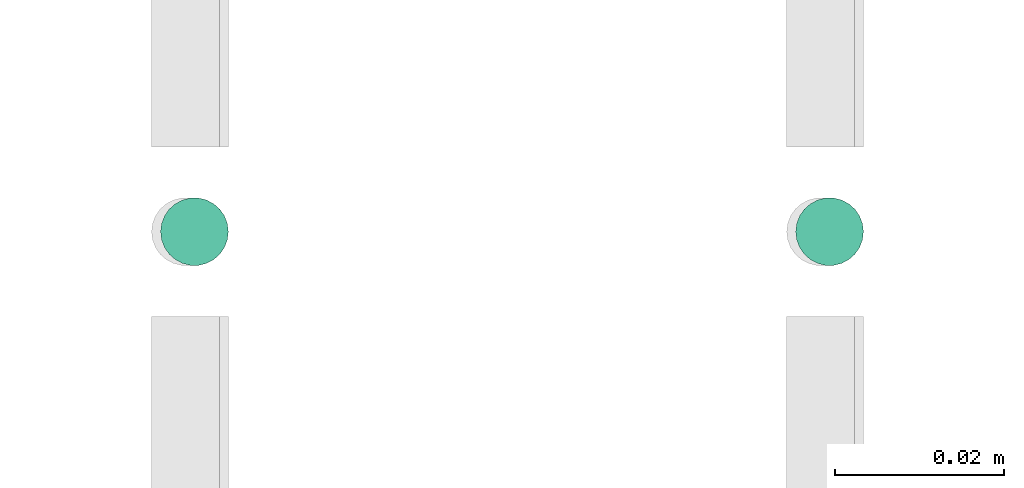
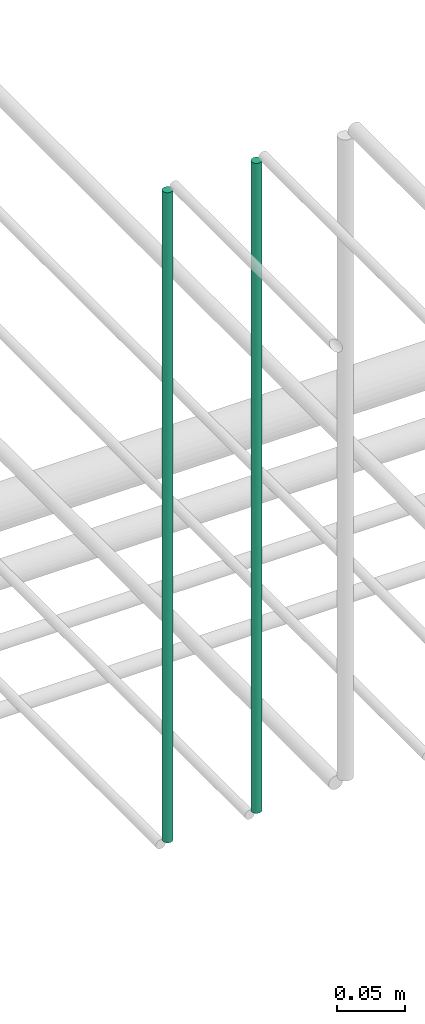
# One storey, part 173 of 331: 2 flow segments.
"""IFC2X3 building model written with IfcOpenShell, lengths in millimetres."""

import ifcopenshell
import ifcopenshell.guid

model = None  # the IFC model being written
_history = None  # IfcOwnerHistory: only IFC2X3 demands one
_inside = {}  # id of a spatial element -> (the spatial element, [elements in it])
_under = {}  # id of a project, library or spatial element -> (it, [spatial elements below it])
_declared = {}  # id of a project -> (the project, [libraries it declares])
_typed = {}  # id of a type object -> (the type object, [elements of that type])
_made_of = {}  # id of a material, layer set ... -> (it, [elements and type objects made of it])


def new_model(schema):
    """Start an empty IFC model of exactly this schema.

    Asked for "IFC4X3", IfcOpenShell would pick the latest addendum, in which some entities
    have other attributes; the version numbers below select the first issue.
    IFC2X3 requires an IfcOwnerHistory on every rooted entity: one is made here for all.
    """
    global model, _history
    if schema == "IFC4X3":
        model = ifcopenshell.file(schema_version=(4, 3, 0, 0))
    else:
        model = ifcopenshell.file(schema=schema)
    _inside.clear()
    _under.clear()
    _declared.clear()
    _typed.clear()
    _made_of.clear()
    _history = None
    if model.schema == "IFC2X3":
        org = make("IfcOrganization", Name="unknown")
        user = make(
            "IfcPersonAndOrganization",
            ThePerson=make("IfcPerson", FamilyName="unknown"),
            TheOrganization=org,
        )
        app = make(
            "IfcApplication",
            ApplicationDeveloper=org,
            Version="unknown",
            ApplicationFullName="unknown",
            ApplicationIdentifier="unknown",
        )
        _history = make(
            "IfcOwnerHistory",
            OwningUser=user,
            OwningApplication=app,
            ChangeAction="ADDED",
            CreationDate=0,
        )
    return model


def make(cls, **values):
    """One entity of the class cls with the attributes given. An attribute that is None is left unset."""
    return model.create_entity(
        cls, **{name: value for name, value in values.items() if value is not None}
    )


def entity(cls, *values):
    """Any entity or typed value of the class cls, its attributes in the order of the schema. None: left unset."""
    e = model.create_entity(cls)
    for i, value in enumerate(values):
        if value is not None:
            e[i] = value
    return e


def rooted(cls, **values):
    """An entity with a GlobalId (a new one), such as an element, a storey or a relation."""
    return make(cls, GlobalId=ifcopenshell.guid.new(), OwnerHistory=_history, **values)


def si_unit(unit_type, name, prefix=None):
    """IfcSIUnit, for example si_unit("LENGTHUNIT", "METRE", prefix="MILLI")."""
    return make("IfcSIUnit", UnitType=unit_type, Prefix=prefix, Name=name)


def converted_unit(unit_type, name, factor, base, dimensions=None, offset=None):
    """IfcConversionBasedUnit, such as the inch: factor (a typed value) times the base unit."""
    return make(
        "IfcConversionBasedUnit"
        if offset is None
        else "IfcConversionBasedUnitWithOffset",
        ConversionOffset=offset,
        Dimensions=None
        if dimensions is None
        else entity("IfcDimensionalExponents", *dimensions),
        UnitType=unit_type,
        Name=name,
        ConversionFactor=make(
            "IfcMeasureWithUnit", ValueComponent=factor, UnitComponent=base
        ),
    )


def derived_unit(unit_type, elements):
    """IfcDerivedUnit: a product of units, each with its exponent."""
    return make(
        "IfcDerivedUnit",
        Elements=[
            make("IfcDerivedUnitElement", Unit=unit, Exponent=power)
            for unit, power in elements
        ],
        UnitType=unit_type,
    )


def assignment(units):
    """IfcUnitAssignment: the units of a project."""
    return None if units is None else make("IfcUnitAssignment", Units=units)


def point(xyz):
    """IfcCartesianPoint."""
    return None if xyz is None else make("IfcCartesianPoint", Coordinates=xyz)


def direction(xyz):
    """IfcDirection."""
    return None if xyz is None else make("IfcDirection", DirectionRatios=xyz)


def frame(location, z_axis=None, x_axis=None):
    """IfcAxis2Placement3D, a coordinate frame: its origin and axes. An axis left out is left unset."""
    return make(
        "IfcAxis2Placement3D",
        Location=point(location),
        Axis=direction(z_axis),
        RefDirection=direction(x_axis),
    )


def frame_2d(location, x_axis=None):
    """IfcAxis2Placement2D, a coordinate frame in the plane: its origin and x axis."""
    return make(
        "IfcAxis2Placement2D", Location=point(location), RefDirection=direction(x_axis)
    )


def origin():
    """The frame at (0, 0, 0) with its axes left unset."""
    return frame((0.0, 0.0, 0.0))


def origin_2d_with_axis():
    """The frame at (0, 0) in the plane with the x axis (1, 0) written out."""
    return frame_2d((0.0, 0.0), x_axis=(1.0, 0.0))


def place(relative_to, where):
    """IfcLocalPlacement: puts the frame where relative to a parent placement (None: the world)."""
    return make(
        "IfcLocalPlacement", PlacementRelTo=relative_to, RelativePlacement=where
    )


def context(
    kind, dimensions, precision=None, world=None, true_north=None, identifier=None
):
    """IfcGeometricRepresentationContext, for example the 3D "Model" context."""
    return make(
        "IfcGeometricRepresentationContext",
        ContextIdentifier=identifier,
        ContextType=kind,
        CoordinateSpaceDimension=dimensions,
        Precision=precision,
        WorldCoordinateSystem=world,
        TrueNorth=true_north,
    )


def subcontext(parent, identifier, kind, view, scale=None):
    """IfcGeometricRepresentationSubContext, for example "Body" below "Model"."""
    return make(
        "IfcGeometricRepresentationSubContext",
        ContextIdentifier=identifier,
        ContextType=kind,
        ParentContext=parent,
        TargetScale=scale,
        TargetView=view,
    )


def project(units=None, contexts=None):
    """IfcProject with its units and contexts."""
    return rooted(
        "IfcProject",
        Name="project",
        RepresentationContexts=contexts,
        UnitsInContext=assignment(units),
    )


def spatial(cls, under=None, at=None, **own):
    """A site, building, storey or space (cls), placed at a placement, below another one or the project."""
    s = rooted(cls, ObjectPlacement=at, **own)
    if under is not None:
        _under.setdefault(under.id(), (under, []))[1].append(s)
    return s


def profile(cls, at=None, kind="AREA", **sizes):
    """A parametric profile (cls). Its sizes go by their IFC names, for example OverallWidth=200.0."""
    return make(cls, ProfileType=kind, Position=at, **sizes)


def circle(**sizes):
    """IfcCircleProfileDef."""
    return profile("IfcCircleProfileDef", **sizes)


def extrude(swept, where, along, depth):
    """IfcExtrudedAreaSolid: the profile swept, set in the frame where, extruded along a direction by depth."""
    return make(
        "IfcExtrudedAreaSolid",
        SweptArea=swept,
        Position=where,
        ExtrudedDirection=direction(along),
        Depth=depth,
    )


def shape(context_of_items, identifier, shape_type, items):
    """IfcShapeRepresentation: the items that make up one representation, for example the "Body"."""
    return make(
        "IfcShapeRepresentation",
        ContextOfItems=context_of_items,
        RepresentationIdentifier=identifier,
        RepresentationType=shape_type,
        Items=items,
    )


def made_of(thing, what):
    """Note that an element or type object is made of a material, layer set ...; save() writes the relation."""
    if what is not None:
        _made_of.setdefault(what.id(), (what, []))[1].append(thing)
    return thing


def type_object(cls, material=None, **own):
    """A type object (cls), such as IfcWallType, which elements share."""
    return made_of(rooted(cls, **own), material)


def element(
    cls,
    number,
    at=None,
    inside=None,
    cuts=None,
    type_object=None,
    material=None,
    context=None,
    identifier="Body",
    shape_type=None,
    held_by="IfcProductDefinitionShape",
    body=None,
    shapes=None,
    **own,
):
    """One element of the class cls, such as IfcWall. Its Tag is "e" and its number.

    at: its placement. inside: the storey or other place that contains it. cuts: it is an
    opening in that element (IfcRelVoidsElement). A single representation is given by context,
    identifier, shape_type and body (its items); several are given by shapes. held_by: the class
    of the entity that holds the representations. save() writes the other relations.
    """
    e = rooted(cls, Tag="e%d" % number, ObjectPlacement=at, **own)
    if body is not None:
        shapes = [shape(context, identifier, shape_type, body)]
    if shapes is not None:
        e.Representation = make(held_by, Representations=shapes)
    if inside is not None:
        _inside.setdefault(inside.id(), (inside, []))[1].append(e)
    if cuts is not None:
        rooted(
            "IfcRelVoidsElement", RelatingBuildingElement=cuts, RelatedOpeningElement=e
        )
    if type_object is not None:
        _typed.setdefault(type_object.id(), (type_object, []))[1].append(e)
    return made_of(e, material)


def aggregate(whole, parts):
    """IfcRelAggregates: a whole, such as a stair, and the parts it consists of."""
    return rooted("IfcRelAggregates", RelatingObject=whole, RelatedObjects=parts)


def save(model, path):
    """Write the relations noted so far, then the file.

    IfcRelAggregates (storeys below a building ...), IfcRelContainedInSpatialStructure (elements
    in a storey), IfcRelDefinesByType, IfcRelAssociatesMaterial and IfcRelDeclares: one each for
    every whole, place, type object, material and project.
    """
    for whole, parts in _under.values():
        aggregate(whole, parts)
    for where, things in _inside.values():
        rooted(
            "IfcRelContainedInSpatialStructure",
            RelatedElements=things,
            RelatingStructure=where,
        )
    for kind, things in _typed.values():
        rooted("IfcRelDefinesByType", RelatedObjects=things, RelatingType=kind)
    for what, things in _made_of.values():
        rooted("IfcRelAssociatesMaterial", RelatedObjects=things, RelatingMaterial=what)
    for by, libraries in _declared.values():
        rooted("IfcRelDeclares", RelatingContext=by, RelatedDefinitions=libraries)
    model.write(path)


model = new_model("IFC2X3")

# Units and contexts
model_context = context("Model", 3, precision=0.01, world=origin(), true_north=direction((6.12303176911189e-17, 1.0)))
body_context = subcontext(model_context, "Body", "Model", "MODEL_VIEW")
ifc_project = project(units=[si_unit("LENGTHUNIT", "METRE", prefix="MILLI"), si_unit("AREAUNIT", "SQUARE_METRE"), si_unit("VOLUMEUNIT", "CUBIC_METRE"), converted_unit("PLANEANGLEUNIT", "DEGREE", entity("IfcRatioMeasure", 0.0174532925199433), si_unit("PLANEANGLEUNIT", "RADIAN"), dimensions=[0, 0, 0, 0, 0, 0, 0]), si_unit("MASSUNIT", "GRAM", prefix="KILO"), derived_unit("MASSDENSITYUNIT", [(si_unit("MASSUNIT", "GRAM", prefix="KILO"), 1), (si_unit("LENGTHUNIT", "METRE"), -3)]), derived_unit("MOMENTOFINERTIAUNIT", [(si_unit("LENGTHUNIT", "METRE"), 4)]), si_unit("TIMEUNIT", "SECOND"), si_unit("FREQUENCYUNIT", "HERTZ"), si_unit("THERMODYNAMICTEMPERATUREUNIT", "DEGREE_CELSIUS"), derived_unit("THERMALTRANSMITTANCEUNIT", [(si_unit("MASSUNIT", "GRAM", prefix="KILO"), 1), (si_unit("THERMODYNAMICTEMPERATUREUNIT", "KELVIN"), -1), (si_unit("TIMEUNIT", "SECOND"), -3)]), derived_unit("VOLUMETRICFLOWRATEUNIT", [(si_unit("LENGTHUNIT", "METRE"), 3), (si_unit("TIMEUNIT", "SECOND"), -1)]), derived_unit("MASSFLOWRATEUNIT", [(si_unit("MASSUNIT", "GRAM", prefix="KILO"), 1), (si_unit("TIMEUNIT", "SECOND"), -1)]), derived_unit("ROTATIONALFREQUENCYUNIT", [(si_unit("TIMEUNIT", "SECOND"), -1)]), si_unit("ELECTRICCURRENTUNIT", "AMPERE"), si_unit("ELECTRICVOLTAGEUNIT", "VOLT"), si_unit("POWERUNIT", "WATT"), si_unit("FORCEUNIT", "NEWTON", prefix="KILO"), si_unit("ILLUMINANCEUNIT", "LUX"), si_unit("LUMINOUSFLUXUNIT", "LUMEN"), si_unit("LUMINOUSINTENSITYUNIT", "CANDELA"), derived_unit("USERDEFINED", [(si_unit("MASSUNIT", "GRAM", prefix="KILO"), -1), (si_unit("LENGTHUNIT", "METRE"), -2), (si_unit("TIMEUNIT", "SECOND"), 3), (si_unit("LUMINOUSFLUXUNIT", "LUMEN"), 1)]), derived_unit("LINEARVELOCITYUNIT", [(si_unit("LENGTHUNIT", "METRE"), 1), (si_unit("TIMEUNIT", "SECOND"), -1)]), si_unit("PRESSUREUNIT", "PASCAL"), derived_unit("USERDEFINED", [(si_unit("LENGTHUNIT", "METRE"), -2), (si_unit("MASSUNIT", "GRAM", prefix="KILO"), 1), (si_unit("TIMEUNIT", "SECOND"), -2)]), derived_unit("LINEARFORCEUNIT", [(si_unit("MASSUNIT", "GRAM", prefix="KILO"), 1), (si_unit("LENGTHUNIT", "METRE"), 1), (si_unit("TIMEUNIT", "SECOND"), -2), (si_unit("LENGTHUNIT", "METRE"), -1)]), derived_unit("PLANARFORCEUNIT", [(si_unit("MASSUNIT", "GRAM", prefix="KILO"), 1), (si_unit("LENGTHUNIT", "METRE"), 1), (si_unit("TIMEUNIT", "SECOND"), -2), (si_unit("LENGTHUNIT", "METRE"), -2)])], contexts=[model_context])

# Site, building, storey
site_placement = place(None, frame((0.0, -0.00077364408347762, 0.0)))
site = spatial("IfcSite", under=ifc_project, at=site_placement, CompositionType="ELEMENT")
building_placement = place(site_placement, origin())
building = spatial("IfcBuilding", under=site, at=building_placement, CompositionType="ELEMENT")
storey_placement = place(building_placement, origin())
storey = spatial("IfcBuildingStorey", under=building, at=storey_placement, CompositionType="ELEMENT", Elevation=0.0)

# Flow segments
pipe_segment_type = type_object("IfcPipeSegmentType", PredefinedType="NOTDEFINED")
flow_segment_1_placement = place(storey_placement, frame((43465.5132590561, 5638.02529159143, 14560.0)))
element("IfcFlowSegment", 1, at=flow_segment_1_placement, inside=storey, type_object=pipe_segment_type, context=body_context, shape_type="SweptSolid", body=[
    extrude(circle(Radius=4.0, at=origin_2d_with_axis()), frame((5.59527223591499, 5.59527223591607, 0.0), z_axis=(0.0, 0.0, 1.0), x_axis=(-1.0, 0.0, 0.0)), (0.0, 0.0, 1.0), 580.000000000026),
])
flow_segment_2_placement = place(storey_placement, frame((43540.5132590561, 5638.02529159143, 14560.0)))
element("IfcFlowSegment", 2, at=flow_segment_2_placement, inside=storey, type_object=pipe_segment_type, context=body_context, shape_type="SweptSolid", body=[
    extrude(circle(Radius=4.0, at=origin_2d_with_axis()), frame((5.59527223591499, 5.59527223591607, 0.0), z_axis=(0.0, 0.0, 1.0), x_axis=(-1.0, 0.0, 0.0)), (0.0, 0.0, 1.0), 580.000000000009),
])

save(model, "model.ifc")
